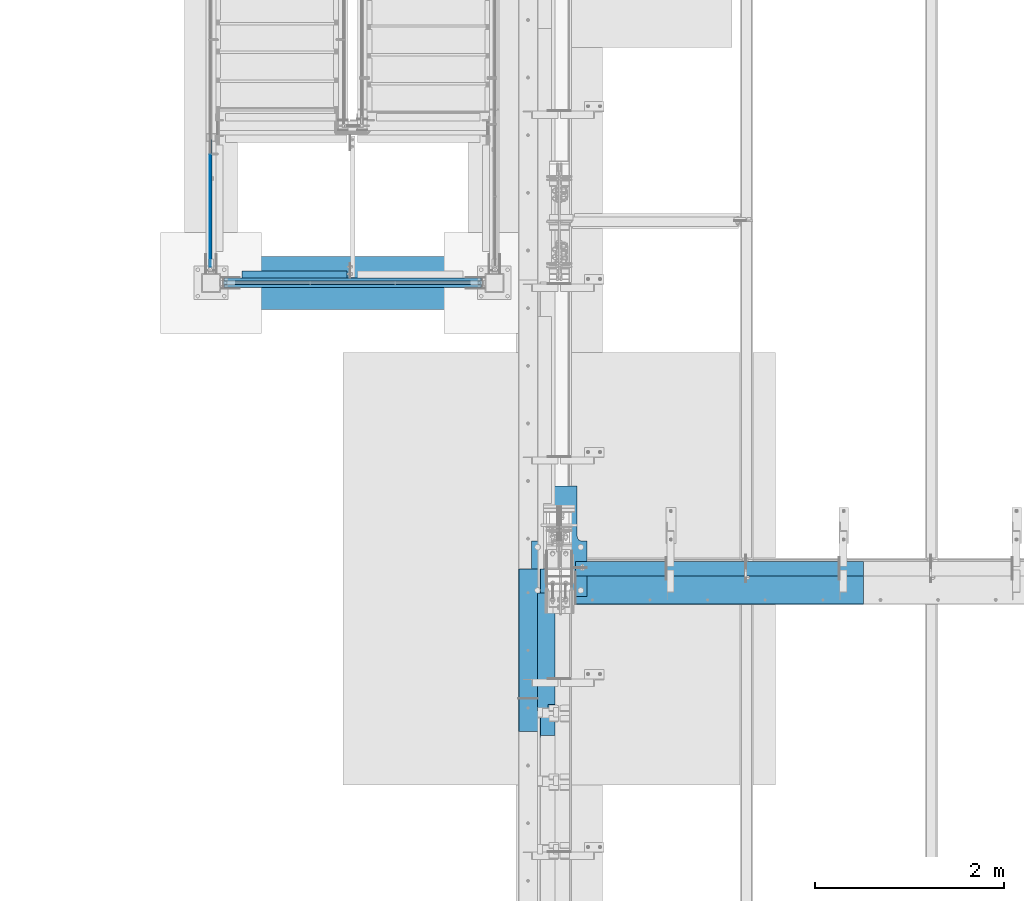
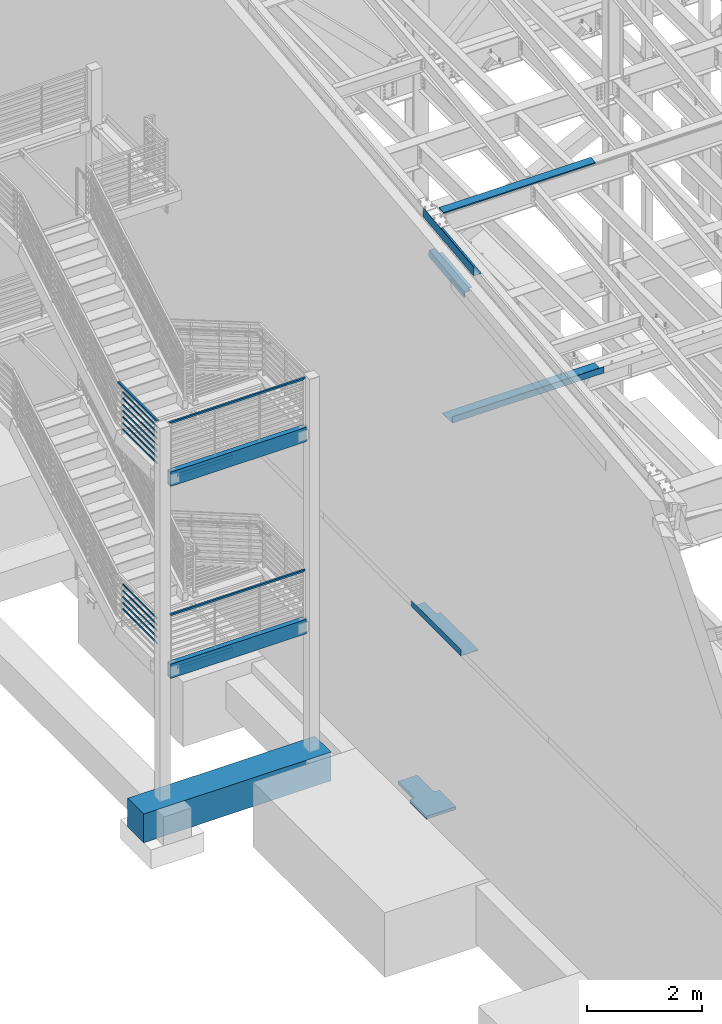
# One storey, part 728 of 1179: 26 beams, 12 elements without a shape of their own.
"""IFC2X3 building model written with IfcOpenShell, lengths in millimetres."""

from ifc_helpers import new_model, si_unit, frame, origin_with_axes, place, context, subcontext, project, spatial, faceted_brep, material, type_object, element, aggregate, save


model = new_model("IFC2X3")

# Units and contexts
model_context = context("Model", 3, precision=1e-05, world=origin_with_axes())
body_context = subcontext(model_context, "Body", "Model", "MODEL_VIEW")
ifc_project = project(units=[si_unit("LENGTHUNIT", "METRE", prefix="MILLI"), si_unit("AREAUNIT", "SQUARE_METRE"), si_unit("VOLUMEUNIT", "CUBIC_METRE"), si_unit("MASSUNIT", "GRAM", prefix="KILO"), si_unit("TIMEUNIT", "SECOND"), si_unit("PLANEANGLEUNIT", "RADIAN"), si_unit("SOLIDANGLEUNIT", "STERADIAN"), si_unit("THERMODYNAMICTEMPERATUREUNIT", "DEGREE_CELSIUS"), si_unit("LUMINOUSINTENSITYUNIT", "LUMEN")], contexts=[model_context])

# Site, building, storey
site_placement = place(None, origin_with_axes())
site = spatial("IfcSite", under=ifc_project, at=site_placement, CompositionType="ELEMENT")
building_placement = place(site_placement, origin_with_axes())
building = spatial("IfcBuilding", under=site, at=building_placement, Name="Undefined", CompositionType="ELEMENT")
storey_placement = place(building_placement, origin_with_axes())
storey = spatial("IfcBuildingStorey", under=building, at=storey_placement, Name="Undefined", CompositionType="ELEMENT", Elevation=0.0)

# Assembly, beam
assembly_1_placement = place(storey_placement, origin_with_axes())
assembly_1 = element("IfcElementAssembly", 1, at=assembly_1_placement, inside=storey, Name="BEAM", AssemblyPlace="NOTDEFINED", PredefinedType="RIGID_FRAME")
ifc_material_1 = material(Name="STEEL/A36")
beam_type_1 = type_object("IfcBeamType", PredefinedType="NOTDEFINED")
beam_1_placement = place(assembly_1_placement, frame((2125.66249999871, 27124.025, 12269.3906249899), z_axis=(-1.0, 0.0, 0.0), x_axis=(0.0, 0.0, 1.0)))
beam_1 = element("IfcBeam", 2, at=beam_1_placement, type_object=beam_type_1, material=ifc_material_1, Name="BENT_PLATE", context=body_context, shape_type="Brep", body=[
    faceted_brep([(-2.91038304567337e-11, -4.76250000000073, -1524.0), (-2.91038304567337e-11, -4.76250000000073, 1524.0), (2.91038304567337e-11, 4.76250000000073, 1524.0), (2.91038304567337e-11, 4.76250000000073, -1524.0), (43.0065173285329, 4.76249999974607, 1524.0), (43.0065173285329, 4.76249999974607, -1524.0), (32.344586885798, -4.7625000001899, -1524.0), (32.344586885798, -4.7625000001899, 1524.0), (25.4267482213236, -150.812499999749, 1524.0), (25.4267482213236, -150.812499999749, -1524.0), (16.9174425672263, -141.287499999748, -1524.0), (16.9174425672263, -141.287499999748, 1524.0), (8.54161044117063e-08, -150.812499999749, 1524.0), (8.54161044117063e-08, -150.812499999749, -1524.0), (8.54161044117063e-08, -141.287499999748, 1524.0), (8.54161044117063e-08, -141.287499999748, -1524.0)], [[[0, 1, 2, 3]], [[3, 2, 4, 5]], [[1, 0, 6, 7]], [[5, 4, 8, 9]], [[7, 6, 10, 11]], [[9, 8, 12, 13]], [[8, 4, 2, 1, 7, 11, 14, 12]], [[11, 10, 15, 14]], [[10, 6, 0, 3, 5, 9, 13, 15]], [[14, 15, 13, 12]]]),
])
aggregate(assembly_1, [beam_1])

# Assembly, beams
assembly_2_placement = place(storey_placement, origin_with_axes())
assembly_2 = element("IfcElementAssembly", 3, at=assembly_2_placement, inside=storey, Name="GUARDRAIL", AssemblyPlace="NOTDEFINED", PredefinedType="RIGID_FRAME")
beam_type_2 = type_object("IfcBeamType", PredefinedType="NOTDEFINED")
beam_2_placement = place(assembly_2_placement, frame((-3257.54999923555, 31436.7380145685, 7131.09462608339), z_axis=(0.0, 0.0, 1.0), x_axis=(0.0, -1.0, 0.0)))
beam_2 = element("IfcBeam", 4, at=beam_2_placement, type_object=beam_type_2, material=ifc_material_1, Name="PLATE", context=body_context, shape_type="Brep", body=[
    faceted_brep([(4.76718123516548, 4.76249999999982, -19.0500000000002), (4.76718123516548, 4.76249999999982, 19.0500000000002), (1191.6880153335, 4.76249999999982, 19.0500000000002), (1191.6880153335, 4.76249999999982, -19.0500000000002), (4.76718123516548, -4.76249999999982, 19.0500000000002), (1191.6880153335, -4.76249999999982, 19.0500000000002), (4.76718123516548, -4.76249999999982, -19.0500000000002), (1191.6880153335, -4.76249999999982, -19.0500000000002)], [[[0, 1, 2, 3]], [[1, 4, 5, 2]], [[4, 6, 7, 5]], [[6, 0, 3, 7]], [[5, 7, 3, 2]], [[6, 4, 1, 0]]]),
])
beam_3_placement = place(assembly_2_placement, frame((-3257.54999923555, 31436.7337030236, 7000.90607249292), z_axis=(0.0, 0.0, 1.0), x_axis=(0.0, -1.0, 0.0)))
beam_3 = element("IfcBeam", 5, at=beam_3_placement, type_object=beam_type_2, material=ifc_material_1, Name="PLATE", context=body_context, shape_type="Brep", body=[
    faceted_brep([(4.76286969025023, 4.76249999999982, -19.0500000000002), (4.76286969025023, 4.76249999999982, 19.0500000000002), (1191.68370378858, 4.76249999999982, 19.0500000000002), (1191.68370378858, 4.76249999999982, -19.0500000000002), (4.76286969025023, -4.76249999999982, 19.0500000000002), (1191.68370378858, -4.76249999999982, 19.0500000000002), (4.76286969025023, -4.76249999999982, -19.0500000000002), (1191.68370378858, -4.76249999999982, -19.0500000000002)], [[[0, 1, 2, 3]], [[1, 4, 5, 2]], [[4, 6, 7, 5]], [[6, 0, 3, 7]], [[5, 7, 3, 2]], [[6, 4, 1, 0]]]),
])
beam_4_placement = place(assembly_2_placement, frame((-3257.54999923555, 31436.7338253545, 6870.70925595731), z_axis=(0.0, 0.0, 1.0), x_axis=(0.0, -1.0, 0.0)))
beam_4 = element("IfcBeam", 6, at=beam_4_placement, type_object=beam_type_2, material=ifc_material_1, Name="PLATE", context=body_context, shape_type="Brep", body=[
    faceted_brep([(4.76299202115842, 4.76249999999982, -19.0500000000002), (4.76299202115842, 4.76249999999982, 19.0500000000002), (1191.68382611949, 4.76249999999982, 19.0500000000002), (1191.68382611949, 4.76249999999982, -19.0500000000002), (4.76299202115842, -4.76249999999982, 19.0500000000002), (1191.68382611949, -4.76249999999982, 19.0500000000002), (4.76299202115842, -4.76249999999982, -19.0500000000002), (1191.68382611949, -4.76249999999982, -19.0500000000002)], [[[0, 1, 2, 3]], [[1, 4, 5, 2]], [[4, 6, 7, 5]], [[6, 0, 3, 7]], [[5, 7, 3, 2]], [[6, 4, 1, 0]]]),
])
beam_5_placement = place(assembly_2_placement, frame((-3257.54999923555, 31436.7339475243, 6740.50828692887), z_axis=(0.0, 0.0, 1.0), x_axis=(0.0, -1.0, 0.0)))
beam_5 = element("IfcBeam", 7, at=beam_5_placement, type_object=beam_type_2, material=ifc_material_1, Name="PLATE", context=body_context, shape_type="Brep", body=[
    faceted_brep([(4.76311419096237, 4.76249999999982, -19.0500000000002), (4.76311419096237, 4.76249999999982, 19.0500000000002), (1191.68394828929, 4.76249999999982, 19.0500000000002), (1191.68394828929, 4.76249999999982, -19.0500000000002), (4.76311419096237, -4.76249999999982, 19.0500000000002), (1191.68394828929, -4.76249999999982, 19.0500000000002), (4.76311419096237, -4.76249999999982, -19.0500000000002), (1191.68394828929, -4.76249999999982, -19.0500000000002)], [[[0, 1, 2, 3]], [[1, 4, 5, 2]], [[4, 6, 7, 5]], [[6, 0, 3, 7]], [[5, 7, 3, 2]], [[6, 4, 1, 0]]]),
])
beam_6_placement = place(assembly_2_placement, frame((-3257.54999923555, 31436.7340699214, 6610.31317642885), z_axis=(0.0, 0.0, 1.0), x_axis=(0.0, -1.0, 0.0)))
beam_6 = element("IfcBeam", 8, at=beam_6_placement, type_object=beam_type_2, material=ifc_material_1, Name="PLATE", context=body_context, shape_type="Brep", body=[
    faceted_brep([(4.76323658805632, 4.76249999999982, -19.0500000000002), (4.76323658805632, 4.76249999999982, 19.0500000000002), (1191.68407068639, 4.76249999999982, 19.0500000000002), (1191.68407068639, 4.76249999999982, -19.0500000000002), (4.76323658805632, -4.76249999999982, 19.0500000000002), (1191.68407068639, -4.76249999999982, 19.0500000000002), (4.76323658805632, -4.76249999999982, -19.0500000000002), (1191.68407068639, -4.76249999999982, -19.0500000000002)], [[[0, 1, 2, 3]], [[1, 4, 5, 2]], [[4, 6, 7, 5]], [[6, 0, 3, 7]], [[5, 7, 3, 2]], [[6, 4, 1, 0]]]),
])
beam_7_placement = place(assembly_2_placement, frame((-3257.54999923555, 31436.7341925986, 6480.12528559629), z_axis=(0.0, 0.0, 1.0), x_axis=(0.0, -1.0, 0.0)))
beam_7 = element("IfcBeam", 9, at=beam_7_placement, type_object=beam_type_2, material=ifc_material_1, Name="PLATE", context=body_context, shape_type="Brep", body=[
    faceted_brep([(4.76335926524189, 4.76249999999982, -19.0500000000002), (4.76335926524189, 4.76249999999982, 19.0500000000002), (1191.68419336357, 4.76249999999982, 19.0500000000002), (1191.68419336357, 4.76249999999982, -19.0500000000002), (4.76335926524189, -4.76249999999982, 19.0500000000002), (1191.68419336357, -4.76249999999982, 19.0500000000002), (4.76335926524189, -4.76249999999982, -19.0500000000002), (1191.68419336357, -4.76249999999982, -19.0500000000002)], [[[0, 1, 2, 3]], [[1, 4, 5, 2]], [[4, 6, 7, 5]], [[6, 0, 3, 7]], [[5, 7, 3, 2]], [[6, 4, 1, 0]]]),
])
beam_8_placement = place(assembly_2_placement, frame((-3257.54999923555, 31436.7333333333, 6349.9999999331), z_axis=(0.0, 0.0, 1.0), x_axis=(0.0, -1.0, 0.0)))
beam_8 = element("IfcBeam", 10, at=beam_8_placement, type_object=beam_type_2, material=ifc_material_1, Name="PLATE", context=body_context, shape_type="Brep", body=[
    faceted_brep([(4.76250000197615, 4.76249999999999, -19.0500000000002), (4.76250000197615, 4.76249999999999, 19.0500000000002), (1191.68333409833, 4.76249999999982, 19.0500000000002), (1191.68333409833, 4.76249999999982, -19.0500000000002), (4.76250000197615, -4.76249999999999, 19.0500000000002), (1191.68333409833, -4.76249999999982, 19.0500000000002), (4.76250000197615, -4.76249999999999, -19.0500000000002), (1191.68333409833, -4.76249999999982, -19.0500000000002)], [[[0, 1, 2, 3]], [[1, 4, 5, 2]], [[4, 6, 7, 5]], [[6, 0, 3, 7]], [[5, 7, 3, 2]], [[6, 4, 1, 0]]]),
])

assembly_3_placement = place(storey_placement, origin_with_axes())
assembly_3 = element("IfcElementAssembly", 11, at=assembly_3_placement, inside=storey, Name="GUARDRAIL", AssemblyPlace="NOTDEFINED", PredefinedType="RIGID_FRAME")
beam_9_placement = place(assembly_3_placement, frame((-3257.54999923555, 31436.7340723971, 3057.55679561595), z_axis=(0.0, 0.0, 1.0), x_axis=(0.0, -1.0, 0.0)))
beam_9 = element("IfcBeam", 12, at=beam_9_placement, type_object=beam_type_2, material=ifc_material_1, Name="PLATE", context=body_context, shape_type="Brep", body=[
    faceted_brep([(4.76323658805632, 4.76249999999982, -19.0500000000002), (4.76323658805632, 4.76249999999982, 19.0500000000002), (1191.68407068639, 4.76249999999982, 19.0500000000002), (1191.68407068639, 4.76249999999982, -19.0500000000002), (4.76323658805632, -4.76249999999982, 19.0500000000002), (1191.68407068639, -4.76249999999982, 19.0500000000002), (4.76323658805632, -4.76249999999982, -19.0500000000002), (1191.68407068639, -4.76249999999982, -19.0500000000002)], [[[0, 1, 2, 3]], [[1, 4, 5, 2]], [[4, 6, 7, 5]], [[6, 0, 3, 7]], [[5, 7, 3, 2]], [[6, 4, 1, 0]]]),
])
beam_10_placement = place(assembly_3_placement, frame((-3257.54999923555, 31436.7340723971, 2927.38179561595), z_axis=(0.0, 0.0, 1.0), x_axis=(0.0, -1.0, 0.0)))
beam_10 = element("IfcBeam", 13, at=beam_10_placement, type_object=beam_type_2, material=ifc_material_1, Name="PLATE", context=body_context, shape_type="Brep", body=[
    faceted_brep([(4.76323658805632, 4.76249999999982, -19.0500000000002), (4.76323658805632, 4.76249999999982, 19.0500000000002), (1191.68407068639, 4.76249999999982, 19.0500000000002), (1191.68407068639, 4.76249999999982, -19.0500000000002), (4.76323658805632, -4.76249999999982, 19.0500000000002), (1191.68407068639, -4.76249999999982, 19.0500000000002), (4.76323658805632, -4.76249999999982, -19.0500000000002), (1191.68407068639, -4.76249999999982, -19.0500000000002)], [[[0, 1, 2, 3]], [[1, 4, 5, 2]], [[4, 6, 7, 5]], [[6, 0, 3, 7]], [[5, 7, 3, 2]], [[6, 4, 1, 0]]]),
])
beam_11_placement = place(assembly_3_placement, frame((-3257.54999923555, 31436.7340723971, 2797.20679561595), z_axis=(0.0, 0.0, 1.0), x_axis=(0.0, -1.0, 0.0)))
beam_11 = element("IfcBeam", 14, at=beam_11_placement, type_object=beam_type_2, material=ifc_material_1, Name="PLATE", context=body_context, shape_type="Brep", body=[
    faceted_brep([(4.76323658805632, 4.76249999999982, -19.0500000000002), (4.76323658805632, 4.76249999999982, 19.0500000000002), (1191.68407068639, 4.76249999999982, 19.0500000000002), (1191.68407068639, 4.76249999999982, -19.0500000000002), (4.76323658805632, -4.76249999999982, 19.0500000000002), (1191.68407068639, -4.76249999999982, 19.0500000000002), (4.76323658805632, -4.76249999999982, -19.0500000000002), (1191.68407068639, -4.76249999999982, -19.0500000000002)], [[[0, 1, 2, 3]], [[1, 4, 5, 2]], [[4, 6, 7, 5]], [[6, 0, 3, 7]], [[5, 7, 3, 2]], [[6, 4, 1, 0]]]),
])
beam_12_placement = place(assembly_3_placement, frame((-3257.54999923555, 31436.7340723971, 2667.03179561595), z_axis=(0.0, 0.0, 1.0), x_axis=(0.0, -1.0, 0.0)))
beam_12 = element("IfcBeam", 15, at=beam_12_placement, type_object=beam_type_2, material=ifc_material_1, Name="PLATE", context=body_context, shape_type="Brep", body=[
    faceted_brep([(4.76323658805632, 4.76249999999982, -19.0500000000002), (4.76323658805632, 4.76249999999982, 19.0500000000002), (1191.68407068639, 4.76249999999982, 19.0500000000002), (1191.68407068639, 4.76249999999982, -19.0500000000002), (4.76323658805632, -4.76249999999982, 19.0500000000002), (1191.68407068639, -4.76249999999982, 19.0500000000002), (4.76323658805632, -4.76249999999982, -19.0500000000002), (1191.68407068639, -4.76249999999982, -19.0500000000002)], [[[0, 1, 2, 3]], [[1, 4, 5, 2]], [[4, 6, 7, 5]], [[6, 0, 3, 7]], [[5, 7, 3, 2]], [[6, 4, 1, 0]]]),
])
beam_13_placement = place(assembly_3_placement, frame((-3257.54999923555, 31436.7340723971, 2536.85679561595), z_axis=(0.0, 0.0, 1.0), x_axis=(0.0, -1.0, 0.0)))
beam_13 = element("IfcBeam", 16, at=beam_13_placement, type_object=beam_type_2, material=ifc_material_1, Name="PLATE", context=body_context, shape_type="Brep", body=[
    faceted_brep([(4.76323658805632, 4.76249999999982, -19.0500000000002), (4.76323658805632, 4.76249999999982, 19.0500000000002), (1191.68407068639, 4.76249999999982, 19.0500000000002), (1191.68407068639, 4.76249999999982, -19.0500000000002), (4.76323658805632, -4.76249999999982, 19.0500000000002), (1191.68407068639, -4.76249999999982, 19.0500000000002), (4.76323658805632, -4.76249999999982, -19.0500000000002), (1191.68407068639, -4.76249999999982, -19.0500000000002)], [[[0, 1, 2, 3]], [[1, 4, 5, 2]], [[4, 6, 7, 5]], [[6, 0, 3, 7]], [[5, 7, 3, 2]], [[6, 4, 1, 0]]]),
])
aggregate(assembly_3, [beam_9, beam_10, beam_11, beam_12, beam_13])

# Assembly, beam
assembly_4_placement = place(storey_placement, origin_with_axes())
assembly_4 = element("IfcElementAssembly", 17, at=assembly_4_placement, inside=storey, Name="GUARDRAIL", AssemblyPlace="NOTDEFINED", PredefinedType="RIGID_FRAME")
ifc_material_2 = material()
beam_type_3 = type_object("IfcBeamType", Name="HSS1-1/2X1-1/2X1/4", PredefinedType="NOTDEFINED")
beam_14_placement = place(assembly_4_placement, frame((-3098.8, 30073.6, 7258.10291935232), z_axis=(0.0, 0.0, 1.0), x_axis=(1.0, 0.0, 0.0)))
beam_14 = element("IfcBeam", 18, at=beam_14_placement, type_object=beam_type_3, material=ifc_material_2, Name="GUARDRAIL", ObjectType="HSS1-1/2X1-1/2X1/4", context=body_context, shape_type="Brep", body=[
    faceted_brep([(12.6999993300014, 12.6999993299978, -12.6999993299996), (12.6999993300014, -12.6999993299978, -12.6999993299996), (2679.70000067, -12.6999993299978, -12.6999993299996), (2679.70000067, 12.6999993299978, -12.6999993299996), (-12.6999993299983, -12.6999993299978, 12.6999993299996), (2705.09999933, -12.6999993299978, 12.6999993299996), (-12.6999993299983, 12.6999993299978, 12.6999993299996), (2705.09999933, 12.6999993299978, 12.6999993299996), (19.0499999999993, 19.0499992349996, -19.0499992350015), (-19.0499992350015, 19.0499992350015, 19.0499992349996), (2711.449999235, 19.0499992350015, 19.0499992349996), (2673.350000765, 19.0499992350015, -19.0499992349996), (-19.0499992350015, -19.0499992350015, 19.0499992349996), (2711.449999235, -19.0499992350015, 19.0499992349996), (19.0499999999993, -19.0499992349996, -19.0499992350015), (2673.350000765, -19.0499992350015, -19.0499992349996)], [[[0, 1, 2, 3]], [[1, 4, 5, 2]], [[4, 6, 7, 5]], [[6, 0, 3, 7]], [[8, 9, 10, 11]], [[9, 12, 13, 10]], [[12, 14, 15, 13]], [[14, 8, 11, 15]], [[13, 15, 11, 10], [5, 7, 3, 2]], [[14, 12, 9, 8], [6, 4, 1, 0]]]),
])
aggregate(assembly_4, [beam_14])

# Beam
beam_15_placement = place(assembly_2_placement, frame((-3257.54999923555, 31590.0170040751, 7258.04999999966), z_axis=(0.0, 3.87960000080057e-05, 0.999999999247435), x_axis=(0.0, -0.999999999247435, 3.87960000097402e-05)))
beam_15 = element("IfcBeam", 19, at=beam_15_placement, type_object=beam_type_3, material=ifc_material_2, Name="GUARDRAIL", ObjectType="HSS1-1/2X1-1/2X1/4", context=body_context, shape_type="Brep", body=[
    faceted_brep([(1.71609454118516, 12.6999993300001, -12.6999993300051), (1.71609454118516, -12.6999993300001, -12.6999993300051), (1351.31651305502, -12.6999993300001, -12.6999993301542), (1351.31651305502, 12.6999993300001, -12.6999993301542), (8.58343246531149, -12.6999993300001, 12.6999993300042), (1376.71749714939, -12.6999993300001, 12.6999993298532), (8.58343246531149, 12.6999993300001, 12.6999993300042), (1376.71749714939, 12.6999993300001, 12.6999993298532), (-0.000740004736144328, 19.0499992350001, -19.0499992350078), (10.3002670112328, 19.0499992350001, 19.0499992350069), (1383.06774341299, 19.0499992350001, 19.049999234855), (1344.96626679142, 19.0499992350001, -19.049999235157), (10.3002670112328, -19.0499992350001, 19.0499992350069), (1383.06774341299, -19.0499992350001, 19.049999234855), (-0.000740004736144328, -19.0499992350001, -19.0499992350078), (1344.96626679142, -19.0499992350001, -19.049999235157)], [[[0, 1, 2, 3]], [[1, 4, 5, 2]], [[4, 6, 7, 5]], [[6, 0, 3, 7]], [[8, 9, 10, 11]], [[9, 12, 13, 10]], [[12, 14, 15, 13]], [[14, 8, 11, 15]], [[13, 15, 11, 10], [5, 7, 3, 2]], [[14, 12, 9, 8], [6, 4, 1, 0]]]),
])

aggregate(assembly_2, [beam_2, beam_3, beam_4, beam_5, beam_6, beam_7, beam_8, beam_15])

# Assembly, beam
assembly_5_placement = place(storey_placement, origin_with_axes())
assembly_5 = element("IfcElementAssembly", 20, at=assembly_5_placement, inside=storey, Name="GUARDRAIL", AssemblyPlace="NOTDEFINED", PredefinedType="RIGID_FRAME")
beam_16_placement = place(assembly_5_placement, frame((-3098.8, 30073.6, 3184.5779190421), z_axis=(0.0, 0.0, 1.0), x_axis=(1.0, 0.0, 0.0)))
beam_16 = element("IfcBeam", 21, at=beam_16_placement, type_object=beam_type_3, material=ifc_material_2, Name="GUARDRAIL", ObjectType="HSS1-1/2X1-1/2X1/4", context=body_context, shape_type="Brep", body=[
    faceted_brep([(12.6999993300014, 12.6999993299978, -12.6999993299996), (12.6999993300014, -12.6999993299978, -12.6999993299996), (2679.70000067, -12.6999993299978, -12.6999993299996), (2679.70000067, 12.6999993299978, -12.6999993299996), (-12.6999993299983, -12.6999993299978, 12.6999993299996), (2705.09999933, -12.6999993299978, 12.6999993299996), (-12.6999993299983, 12.6999993299978, 12.6999993299996), (2705.09999933, 12.6999993299978, 12.6999993299996), (19.0499999999993, 19.0499992349996, -19.0499992350015), (-19.0499992350015, 19.0499992350015, 19.0499992349996), (2711.449999235, 19.0499992350015, 19.0499992349996), (2673.350000765, 19.0499992350015, -19.0499992349996), (-19.0499992350015, -19.0499992350015, 19.0499992349996), (2711.449999235, -19.0499992350015, 19.0499992349996), (19.0499999999993, -19.0499992349996, -19.0499992350015), (2673.350000765, -19.0499992350015, -19.0499992349996)], [[[0, 1, 2, 3]], [[1, 4, 5, 2]], [[4, 6, 7, 5]], [[6, 0, 3, 7]], [[8, 9, 10, 11]], [[9, 12, 13, 10]], [[12, 14, 15, 13]], [[14, 8, 11, 15]], [[13, 15, 11, 10], [5, 7, 3, 2]], [[14, 12, 9, 8], [6, 4, 1, 0]]]),
])
aggregate(assembly_5, [beam_16])

assembly_6_placement = place(storey_placement, origin_with_axes())
assembly_6 = element("IfcElementAssembly", 22, at=assembly_6_placement, inside=storey, Name="BEAM", AssemblyPlace="NOTDEFINED", PredefinedType="RIGID_FRAME")
beam_type_4 = type_object("IfcBeamType", Name="L3X3X1/4", PredefinedType="NOTDEFINED")
beam_17_placement = place(assembly_6_placement, frame((-2921.0, 30162.5, 1978.025), z_axis=(0.0, 0.0, -1.0), x_axis=(1.0, 0.0, 0.0)))
beam_17 = element("IfcBeam", 23, at=beam_17_placement, type_object=beam_type_4, material=ifc_material_1, Name="ANGLE", ObjectType="L3X3X1/4", context=body_context, shape_type="Brep", body=[
    faceted_brep([(0.0, 38.0999999999985, -38.0999999999999), (0.0, 38.0999999999985, 38.0999999999999), (1109.6625, 38.0999999999985, 38.0999999999999), (1109.6625, 38.0999999999985, -38.0999999999999), (0.0, 31.75, 38.1000000000004), (1109.6625, 31.75, 38.0999999999999), (0.0, 31.75, -31.75), (1109.6625, 31.75, -31.75), (0.0, -38.0999999999985, -31.75), (1109.6625, -38.0999999999985, -31.75), (0.0, -38.0999999999985, -38.0999999999999), (1109.6625, -38.0999999999985, -38.0999999999999)], [[[0, 1, 2, 3]], [[1, 4, 5, 2]], [[4, 6, 7, 5]], [[6, 8, 9, 7]], [[8, 10, 11, 9]], [[10, 0, 3, 11]], [[5, 7, 9, 11, 3, 2]], [[10, 8, 6, 4, 1, 0]]]),
])

assembly_7_placement = place(storey_placement, origin_with_axes())
assembly_7 = element("IfcElementAssembly", 24, at=assembly_7_placement, inside=storey, Name="BEAM", AssemblyPlace="NOTDEFINED", PredefinedType="RIGID_FRAME")
beam_18_placement = place(assembly_7_placement, frame((-2921.0, 30162.5, 6051.55), z_axis=(0.0, 0.0, -1.0), x_axis=(1.0, 0.0, 0.0)))
beam_18 = element("IfcBeam", 25, at=beam_18_placement, type_object=beam_type_4, material=ifc_material_1, Name="ANGLE", ObjectType="L3X3X1/4", context=body_context, shape_type="Brep", body=[
    faceted_brep([(0.0, 38.0999999999985, -38.0999999999999), (0.0, 38.0999999999985, 38.0999999999999), (1109.6625, 38.0999999999985, 38.0999999999999), (1109.6625, 38.0999999999985, -38.0999999999999), (0.0, 31.75, 38.1000000000004), (1109.6625, 31.75, 38.0999999999999), (0.0, 31.75, -31.75), (1109.6625, 31.75, -31.75), (0.0, -38.0999999999985, -31.75), (1109.6625, -38.0999999999985, -31.75), (0.0, -38.0999999999985, -38.0999999999999), (1109.6625, -38.0999999999985, -38.0999999999999)], [[[0, 1, 2, 3]], [[1, 4, 5, 2]], [[4, 6, 7, 5]], [[6, 8, 9, 7]], [[8, 10, 11, 9]], [[10, 0, 3, 11]], [[5, 7, 9, 11, 3, 2]], [[10, 8, 6, 4, 1, 0]]]),
])

assembly_8_placement = place(storey_placement, origin_with_axes())
assembly_8 = element("IfcElementAssembly", 26, at=assembly_8_placement, inside=storey, Name="BEAM", AssemblyPlace="NOTDEFINED", PredefinedType="RIGID_FRAME")
beam_type_5 = type_object("IfcBeamType", PredefinedType="NOTDEFINED")
beam_19_placement = place(assembly_8_placement, frame((388.937000026495, 26167.3979851463, 12206.9566078406), z_axis=(0.0, -0.993676146336441, -0.112284087038017), x_axis=(-1.0, 0.0, 0.0)))
beam_19 = element("IfcBeam", 27, at=beam_19_placement, type_object=beam_type_5, material=ifc_material_1, Name="BENT_PLATE", context=body_context, shape_type="Brep", body=[
    faceted_brep([(71.4370275460877, -3.17499999980828, -469.696154964691), (71.4370618736331, 3.17447699928925, -469.696152210432), (71.4369522855089, 3.17500000035579, -885.031499999506), (71.4369179576251, -3.17499999963911, -885.031499999513), (0.0, -3.17499999980828, -469.696140440821), (0.0, 3.17500000018663, -469.696137686398), (160.336999996553, 3.17499999963911, 885.031499999503), (0.0, 3.17499999963911, 885.031499999503), (0.0, -3.17500000035761, 885.031499999495), (153.986999996553, -3.17500000035761, 885.031499999495), (153.986999996553, -187.32499999641, 885.031499999423), (160.336999996553, -187.32499999641, 885.031499999423), (160.336999996553, 3.17500000035579, -885.031499999506), (160.336999996553, -187.324999995692, -885.031499999583), (153.986999996553, -187.324999995692, -885.031499999583), (153.986999996553, -3.17499999963911, -885.031499999513)], [[[0, 1, 2, 3]], [[4, 5, 1, 0]], [[6, 7, 8, 9, 10, 11]], [[12, 6, 11, 13]], [[10, 14, 13, 11]], [[9, 15, 14, 10]], [[12, 13, 14, 15, 3, 2]], [[7, 6, 12, 2, 1, 5]], [[8, 7, 5, 4]], [[15, 9, 8, 4, 0, 3]]]),
])

# Beam
beam_type_6 = type_object("IfcBeamType", Name="HSS12X4X3/8", PredefinedType="NOTDEFINED")
beam_20_placement = place(assembly_7_placement, frame((-3251.2, 30073.6, 6089.65), z_axis=(0.0, 0.0, 1.0), x_axis=(1.0, 0.0, 0.0)))
beam_20 = element("IfcBeam", 28, at=beam_20_placement, type_object=beam_type_6, material=ifc_material_2, Name="BEAM", ObjectType="HSS12X4X3/8", context=body_context, shape_type="Brep", body=[
    faceted_brep([(136.525, 41.2750000000015, -142.875), (136.525, -41.2750000000015, -142.875), (2860.675, -41.2750000000015, -142.875), (2860.675, 41.2750000000015, -142.875), (136.525, -41.2750000000015, 142.875), (2860.675, -41.2750000000015, 142.875), (136.525, 41.2750000000015, 142.875), (2860.675, 41.2750000000015, 142.875), (136.525, 50.7999999999993, -152.4), (136.525, 50.7999999999993, 152.4), (2860.675, 50.7999999999993, 152.4), (2860.675, 50.7999999999993, -152.4), (136.525, -50.7999999999993, 152.4), (2860.675, -50.7999999999993, 152.4), (136.525, -50.7999999999993, -152.4), (2860.675, -50.7999999999993, -152.4)], [[[0, 1, 2, 3]], [[1, 4, 5, 2]], [[4, 6, 7, 5]], [[6, 0, 3, 7]], [[8, 9, 10, 11]], [[9, 12, 13, 10]], [[12, 14, 15, 13]], [[14, 8, 11, 15]], [[13, 15, 11, 10], [5, 7, 3, 2]], [[14, 12, 9, 8], [6, 4, 1, 0]]]),
])

aggregate(assembly_7, [beam_18, beam_20])

beam_21_placement = place(assembly_6_placement, frame((-3251.2, 30073.6, 2016.125), z_axis=(0.0, 0.0, 1.0), x_axis=(1.0, 0.0, 0.0)))
beam_21 = element("IfcBeam", 29, at=beam_21_placement, type_object=beam_type_6, material=ifc_material_2, Name="BEAM", ObjectType="HSS12X4X3/8", context=body_context, shape_type="Brep", body=[
    faceted_brep([(136.525, 41.2750000000015, -142.875), (136.525, -41.2750000000015, -142.875), (2860.675, -41.2750000000015, -142.875), (2860.675, 41.2750000000015, -142.875), (136.525, -41.2750000000015, 142.875), (2860.675, -41.2750000000015, 142.875), (136.525, 41.2750000000015, 142.875), (2860.675, 41.2750000000015, 142.875), (136.525, 50.7999999999993, -152.4), (136.525, 50.7999999999993, 152.4), (2860.675, 50.7999999999993, 152.4), (2860.675, 50.7999999999993, -152.4), (136.525, -50.7999999999993, 152.4), (2860.675, -50.7999999999993, 152.4), (136.525, -50.7999999999993, -152.4), (2860.675, -50.7999999999993, -152.4)], [[[0, 1, 2, 3]], [[1, 4, 5, 2]], [[4, 6, 7, 5]], [[6, 0, 3, 7]], [[8, 9, 10, 11]], [[9, 12, 13, 10]], [[12, 14, 15, 13]], [[14, 8, 11, 15]], [[13, 15, 11, 10], [5, 7, 3, 2]], [[14, 12, 9, 8], [6, 4, 1, 0]]]),
])

aggregate(assembly_6, [beam_17, beam_21])

# Assembly, beam
assembly_9_placement = place(storey_placement, origin_with_axes())
assembly_9 = element("IfcElementAssembly", 30, at=assembly_9_placement, inside=storey, Name="BEAM", AssemblyPlace="NOTDEFINED", PredefinedType="RIGID_FRAME")
beam_type_7 = type_object("IfcBeamType", PredefinedType="NOTDEFINED")
beam_22_placement = place(assembly_9_placement, frame((2125.66246123732, 26673.175, 8147.05000610352), z_axis=(1.0, 0.0, 0.0), x_axis=(0.0, 0.0, -1.0)))
beam_22 = element("IfcBeam", 31, at=beam_22_placement, type_object=beam_type_7, material=ifc_material_1, Name="BENT_PLATE", context=body_context, shape_type="Brep", body=[
    faceted_brep([(0.0, -3.17499999999927, -1524.0), (6.00266503170133e-10, -3.17499999922438, 1524.00000000052), (6.00266503170133e-10, 3.17500000077416, 1524.00000000052), (0.0, 3.17499999999927, -1524.0), (127.000006103516, 3.17499999999927, 1524.0), (127.000006103516, 3.17499999999927, -1524.0), (133.350006103517, -3.17499999999927, -1524.0), (133.350006103517, -3.17499999999927, 1524.0), (127.000006103516, 346.074999237058, 1524.0), (127.000006103516, 346.074999237058, -1524.0), (133.350006103517, 346.074999237058, 1524.0), (133.350006103517, 346.074999237058, -1524.0)], [[[0, 1, 2, 3]], [[3, 2, 4, 5]], [[1, 0, 6, 7]], [[5, 4, 8, 9]], [[4, 2, 1, 7, 10, 8]], [[7, 6, 11, 10]], [[6, 0, 3, 5, 9, 11]], [[10, 11, 9, 8]]]),
])
aggregate(assembly_9, [beam_22])

# Beam
beam_type_8 = type_object("IfcBeamType", PredefinedType="NOTDEFINED")
beam_23_placement = place(assembly_8_placement, frame((388.937000048195, 26169.0533384615, 11678.3376825668), z_axis=(0.0, -0.993676146336441, -0.112284087038017), x_axis=(-1.0, 0.0, 0.0)))
beam_23 = element("IfcBeam", 32, at=beam_23_placement, type_object=beam_type_8, material=ifc_material_1, Name="BENT_PLATE", context=body_context, shape_type="Brep", body=[
    faceted_brep([(76.1995000476055, -3.1744942563837, -481.012500015386), (76.1995000476055, 3.17611935736568, -481.012500017867), (76.1995000488168, 3.17499999973916, -627.062499999662), (76.1995000488168, -3.17500000025575, -627.062499999654), (0.0, -3.17500000019209, -481.012500018212), (0.0, 3.17499999980464, -481.012500015735), (76.1995000478943, -3.1754727664902, 558.085432711836), (76.1995000478943, 3.17514084725917, 558.085432709278), (-1.13686837721616e-13, 3.1749999997719, 558.085432709275), (1.13686837721616e-13, -3.17500000022483, 558.085432711836), (76.1995000478943, -3.17523391229406, 627.062500000455), (76.1995000491042, 3.17500000024665, 627.06249999964), (185.737000047376, -3.17500000024484, 627.062499999643), (185.737000047377, 136.524999949006, 627.062499999698), (179.387000047377, 136.524999949006, 627.062499999698), (179.387000047376, 3.17499999975189, 627.062499999647), (179.387000047376, 3.17500000025757, -627.062499999651), (179.387000047377, 136.524999949514, -627.062499999596), (185.737000047377, 136.524999949514, -627.062499999596), (185.737000047376, -3.17499999973734, -627.062499999654)], [[[0, 1, 2, 3]], [[4, 5, 1, 0]], [[6, 7, 8, 9]], [[10, 11, 7, 6]], [[12, 13, 14, 15, 11, 10]], [[16, 15, 14, 17]], [[13, 18, 17, 14]], [[12, 19, 18, 13]], [[16, 17, 18, 19, 3, 2]], [[8, 7, 11, 15, 16, 2, 1, 5]], [[9, 8, 5, 4]], [[19, 12, 10, 6, 9, 4, 0, 3]]]),
])

aggregate(assembly_8, [beam_19, beam_23])

# Assembly, beam
assembly_10_placement = place(storey_placement, origin_with_axes())
assembly_10 = element("IfcElementAssembly", 33, at=assembly_10_placement, inside=storey, Name="BEAM", AssemblyPlace="NOTDEFINED", PredefinedType="RIGID_FRAME")
beam_type_9 = type_object("IfcBeamType", PredefinedType="NOTDEFINED")
beam_24_placement = place(assembly_10_placement, frame((352.424987792969, 26187.4, 4105.275), z_axis=(0.0, -1.0, 0.0), x_axis=(-1.0, 0.0, 0.0)))
beam_24 = element("IfcBeam", 34, at=beam_24_placement, type_object=beam_type_9, material=ifc_material_1, Name="BENT_PLATE", context=body_context, shape_type="Brep", body=[
    faceted_brep([(84.1374893188477, -3.17500000000018, -457.200006103518), (84.1374893188477, 3.17500000000018, -457.200006103518), (84.1374893188477, 3.17500000000018, -860.424999999999), (84.1374893188477, -3.17500000000018, -860.424999999999), (0.0, -3.17500000000018, -457.200006103518), (0.0, 3.17500000000018, -457.200006103518), (352.424987792969, 3.17499999999927, 860.424999999999), (0.0, 3.17500000000018, 860.424999999999), (0.0, -3.17500000000018, 860.424999999999), (346.074987792969, -3.17500000000109, 860.424999999999), (346.074987792969, -130.175006103515, 860.424999999999), (352.424987792969, -130.175006103515, 860.424999999999), (352.424987792969, 3.17499999999927, -860.424999999999), (352.424987792969, -130.175006103515, -860.424999999999), (346.074987792969, -130.175006103515, -860.424999999999), (346.074987792969, -3.17500000000109, -860.424999999999)], [[[0, 1, 2, 3]], [[4, 5, 1, 0]], [[6, 7, 8, 9, 10, 11]], [[12, 6, 11, 13]], [[10, 14, 13, 11]], [[9, 15, 14, 10]], [[12, 13, 14, 15, 3, 2]], [[7, 6, 12, 2, 1, 5]], [[8, 7, 5, 4]], [[15, 9, 8, 4, 0, 3]]]),
])
aggregate(assembly_10, [beam_24])

assembly_11_placement = place(storey_placement, origin_with_axes())
assembly_11 = element("IfcElementAssembly", 35, at=assembly_11_placement, inside=storey, Name="GRADE_BEAM", AssemblyPlace="NOTDEFINED", PredefinedType="REINFORCEMENT_UNIT")
ifc_material_3 = material(Name="CONCRETE/5000")
beam_type_10 = type_object("IfcBeamType", PredefinedType="NOTDEFINED")
beam_25_placement = place(assembly_11_placement, frame((-3784.6, 30073.6, -939.8), z_axis=(0.0, 0.0, 1.0), x_axis=(1.0, 0.0, 0.0)))
beam_25 = element("IfcBeam", 36, at=beam_25_placement, type_object=beam_type_10, material=ifc_material_3, Name="GRADE_BEAM", context=body_context, shape_type="Brep", body=[
    faceted_brep([(0.0, 279.4, -304.8), (0.0, 279.4, 304.8), (3759.2, 279.400000000001, 304.8), (3759.2, 279.400000000001, -304.8), (0.0, -279.4, 304.8), (3759.2, -279.400000000001, 304.8), (0.0, -279.4, -304.8), (3759.2, -279.400000000001, -304.8)], [[[0, 1, 2, 3]], [[1, 4, 5, 2]], [[4, 6, 7, 5]], [[6, 0, 3, 7]], [[5, 7, 3, 2]], [[6, 4, 1, 0]]]),
])
aggregate(assembly_11, [beam_25])

assembly_12_placement = place(storey_placement, origin_with_axes())
assembly_12 = element("IfcElementAssembly", 37, at=assembly_12_placement, inside=storey, Name="COLUMN", AssemblyPlace="NOTDEFINED", PredefinedType="RIGID_FRAME")
ifc_material_4 = material(Name="STEEL/A572-GR.50")
beam_type_11 = type_object("IfcBeamType", PredefinedType="NOTDEFINED")
beam_26_placement = place(assembly_12_placement, frame((431.799999999996, 26758.90050354, -247.65), z_axis=(-1.0, 0.0, 0.0), x_axis=(0.0, 1.0, 0.0)))
beam_26 = element("IfcBeam", 38, at=beam_26_placement, type_object=beam_type_11, material=ifc_material_4, context=body_context, shape_type="Brep", body=[
    faceted_brep([(584.199496459958, -31.75, 292.1), (584.199496459958, -31.75, 241.30000076336), (584.199496459958, 31.75, 241.30000076336), (584.199496459958, 31.75, 292.1), (588.066416150308, -31.75, 221.859682691178), (588.066416150308, 31.75, 221.859682691178), (599.078471752222, -31.75, 205.378976818563), (599.078471752222, 31.75, 205.378976818563), (615.559177624837, -31.75, 194.366921216651), (615.559177624837, 31.75, 194.366921216651), (634.999495697019, -31.75, 190.500001526299), (634.999495697019, 31.75, 190.500001526299), (1168.39847106933, -31.75, 190.500001526299), (1168.39848937988, 31.75, 190.500001526299), (0.0, -31.75, -292.1), (0.0, -31.75, 292.1), (0.0, 31.75, 292.1), (0.0, 31.75, -292.1), (584.199496459958, 31.75, -292.1), (584.199496459958, -31.75, -292.1), (584.199496459958, 31.75, -241.30000076336), (584.199496459958, -31.75, -241.30000076336), (588.066416150308, 31.75, -221.859682691178), (588.066416150308, -31.75, -221.859682691178), (599.078471752222, 31.75, -205.378976818563), (599.078471752222, -31.75, -205.378976818563), (615.559177624837, 31.75, -194.366921216651), (615.559177624837, -31.75, -194.366921216651), (634.999495697019, 31.75, -190.500001526299), (634.999495697019, -31.75, -190.500001526299), (1168.39847106933, -31.75, -190.500001526299), (1168.39848937988, 31.75, -190.500001526299)], [[[0, 1, 2, 3]], [[4, 5, 2, 1]], [[6, 7, 5, 4]], [[8, 9, 7, 6]], [[10, 11, 9, 8]], [[12, 13, 11, 10]], [[14, 15, 16, 17]], [[14, 17, 18, 19]], [[19, 18, 20, 21]], [[21, 20, 22, 23]], [[23, 22, 24, 25]], [[25, 24, 26, 27]], [[27, 26, 28, 29]], [[30, 29, 28, 31]], [[8, 6, 4, 1, 0, 15, 14, 19, 21, 23, 25, 27, 29, 30, 12, 10]], [[16, 15, 0, 3]], [[31, 28, 26, 24, 22, 20, 18, 17, 16, 3, 2, 5, 7, 9, 11, 13]], [[30, 31, 13, 12]]]),
])
aggregate(assembly_12, [beam_26])

save(model, "model.ifc")
